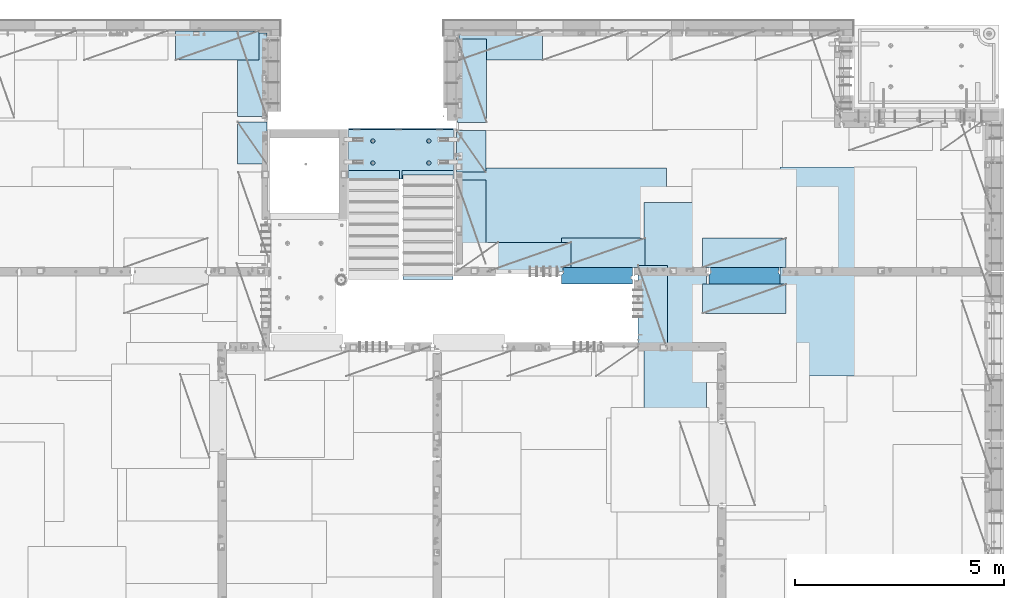
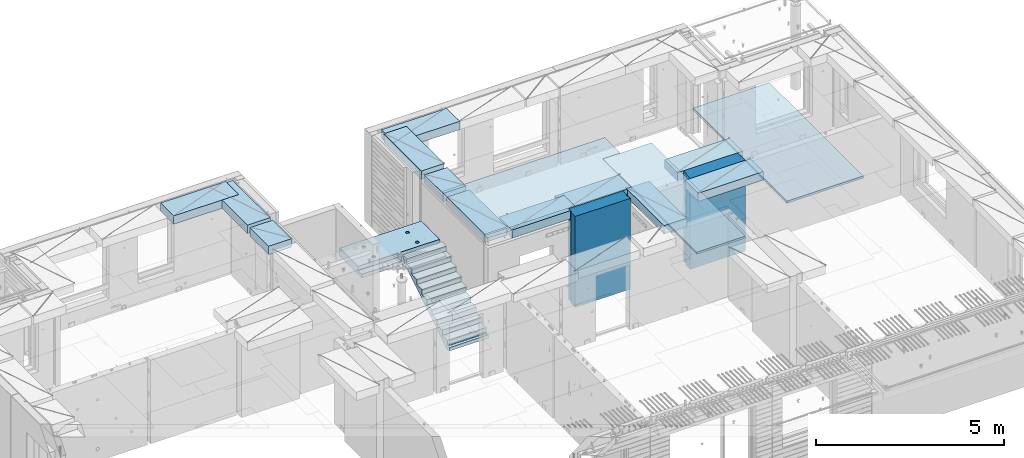
# One storey, part 200 of 334: 18 plates, 1 slab, 19 elements without a shape of their own.
"""IFC2X3 building model written with IfcOpenShell, lengths in millimetres."""

from ifc_helpers import new_model, si_unit, frame, origin_with_axes, place, context, subcontext, project, spatial, faceted_brep, material, type_object, element, aggregate, save


model = new_model("IFC2X3")

# Units and contexts
model_context = context("Model", 3, precision=1e-05, world=origin_with_axes())
body_context = subcontext(model_context, "Body", "Model", "MODEL_VIEW")
ifc_project = project(units=[si_unit("LENGTHUNIT", "METRE", prefix="MILLI"), si_unit("AREAUNIT", "SQUARE_METRE"), si_unit("VOLUMEUNIT", "CUBIC_METRE"), si_unit("MASSUNIT", "GRAM", prefix="KILO"), si_unit("TIMEUNIT", "SECOND"), si_unit("PLANEANGLEUNIT", "RADIAN"), si_unit("SOLIDANGLEUNIT", "STERADIAN"), si_unit("THERMODYNAMICTEMPERATUREUNIT", "DEGREE_CELSIUS"), si_unit("LUMINOUSINTENSITYUNIT", "LUMEN")], contexts=[model_context])

# Site, building, storey
site_placement = place(None, origin_with_axes())
site = spatial("IfcSite", under=ifc_project, at=site_placement, CompositionType="ELEMENT")
building_placement = place(site_placement, origin_with_axes())
building = spatial("IfcBuilding", under=site, at=building_placement, CompositionType="ELEMENT")
storey_placement = place(building_placement, origin_with_axes())
storey = spatial("IfcBuildingStorey", under=building, at=storey_placement, Name="3", CompositionType="ELEMENT", Elevation=0.0)

# Assembly, plate
assembly_1_placement = place(storey_placement, origin_with_axes())
assembly_1 = element("IfcElementAssembly", 1, at=assembly_1_placement, inside=storey, Name="E9", AssemblyPlace="NOTDEFINED", PredefinedType="NOTDEFINED")
ifc_material_1 = material(Name="Undefined/C32/40")
plate_type_1 = type_object("IfcPlateType", PredefinedType="NOTDEFINED")
plate_1_placement = place(assembly_1_placement, frame((21585.002175553, 16880.001025346, 87759.7036072969), z_axis=(0.0, 1.0, 0.0), x_axis=(0.0, 0.0, -1.0)))
plate_1 = element("IfcPlate", 2, at=plate_1_placement, type_object=plate_type_1, material=ifc_material_1, Name="E9", context=body_context, shape_type="Brep", body=[
    faceted_brep([(0.0, -600.0, 0.0), (0.0, -600.0, 30.0), (0.0, 600.0, 30.0), (0.0, 600.0, 0.0), (-136.699996948242, -600.0, 30.0), (-136.699996948242, 600.0, 30.0), (-136.699996948242, -600.0, 300.0), (-136.699996948242, 600.0, 300.0), (-303.399993896484, -600.0, 300.0), (-303.399993896484, 600.0, 300.0), (-303.399993896484, -600.0, 570.0), (-303.399993896484, 600.0, 570.0), (-470.100006103516, -600.0, 570.0), (-470.100006103516, 600.0, 570.0), (-470.100006103516, -600.0, 840.0), (-470.100006103516, 600.0, 840.0), (-636.799987792969, -600.0, 840.0), (-636.799987792969, 600.0, 840.0), (-636.799987792969, -600.0, 1110.0), (-636.799987792969, 600.0, 1110.0), (-803.5, -600.0, 1110.0), (-803.5, 600.0, 1110.0), (-803.5, -600.0, 1380.0), (-803.5, 600.0, 1380.0), (-970.200012207031, -600.0, 1380.0), (-970.200012207031, 600.0, 1380.0), (-970.200012207031, -600.0, 1650.0), (-970.200012207031, 600.0, 1650.0), (-1136.90002441406, -600.0, 1650.0), (-1136.90002441406, 600.0, 1650.0), (-1136.90002441406, -600.0, 1920.0), (-1136.90002441406, 600.0, 1920.0), (-1303.59997558594, -600.0, 1920.0), (-1303.59997558594, 600.0, 1920.0), (-1303.59997558594, -600.0, 2190.0), (-1303.59997558594, 600.0, 2190.0), (-1470.30004882813, -600.0, 2190.0), (-1470.30004882813, 600.0, 2190.0), (-1470.30004882813, -600.0, 2410.0), (-1470.30004882813, 600.0, 2410.0), (-1370.30004882813, -600.0, 2410.0), (-1370.30004882813, 600.0, 2410.0), (-1370.30004882813, -600.0, 2310.0), (-1370.30004882813, 600.0, 2310.0), (-1236.65991210938, -600.0, 2310.0), (-1236.65991210938, 600.0, 2310.0), (170.0, -600.0, 31.6665592193604), (170.0, 600.0, 31.6665592193604), (170.0, -600.0, 20.0), (170.0, 600.0, 20.0), (135.0, -600.0, 20.0), (135.0, 600.0, 20.0), (135.0, -600.0, -90.0), (135.0, 600.0, -90.0), (25.0, -600.0, -90.0), (25.0, 600.0, -90.0), (25.0, -600.0, 0.0), (25.0, 600.0, 0.0)], [[[0, 1, 2, 3]], [[1, 4, 5, 2]], [[4, 6, 7, 5]], [[6, 8, 9, 7]], [[8, 10, 11, 9]], [[10, 12, 13, 11]], [[12, 14, 15, 13]], [[14, 16, 17, 15]], [[16, 18, 19, 17]], [[18, 20, 21, 19]], [[20, 22, 23, 21]], [[22, 24, 25, 23]], [[24, 26, 27, 25]], [[26, 28, 29, 27]], [[28, 30, 31, 29]], [[30, 32, 33, 31]], [[32, 34, 35, 33]], [[34, 36, 37, 35]], [[36, 38, 39, 37]], [[38, 40, 41, 39]], [[40, 42, 43, 41]], [[42, 44, 45, 43]], [[44, 46, 47, 45]], [[46, 48, 49, 47]], [[48, 50, 51, 49]], [[50, 52, 53, 51]], [[52, 54, 55, 53]], [[54, 56, 57, 55]], [[56, 0, 3, 57]], [[5, 7, 9, 11, 13, 15, 17, 19, 21, 23, 25, 27, 29, 31, 33, 35, 37, 39, 41, 43, 45, 47, 49, 51, 53, 55, 57, 3, 2]], [[56, 54, 52, 50, 48, 46, 44, 42, 40, 38, 36, 34, 32, 30, 28, 26, 24, 22, 20, 18, 16, 14, 12, 10, 8, 6, 4, 1, 0]]]),
])
aggregate(assembly_1, [plate_1])

# Assembly, slab
assembly_2_placement = place(storey_placement, origin_with_axes())
assembly_2 = element("IfcElementAssembly", 3, at=assembly_2_placement, inside=storey, AssemblyPlace="NOTDEFINED", PredefinedType="REINFORCEMENT_UNIT")
ifc_material_2 = material(Name="CONCRETE/C25/30")
slab_type = type_object("IfcSlabType", PredefinedType="NOTDEFINED")
slab_placement = place(assembly_2_placement, frame((19680.000385927, 19200.0003517906, 89120.0), z_axis=(0.0, 1.0, 0.0), x_axis=(1.0, 0.0, 0.0)))
slab = element("IfcSlab", 4, at=slab_placement, type_object=slab_type, material=ifc_material_2, PredefinedType="FLOOR", context=body_context, shape_type="Brep", body=[
    faceted_brep([(1284.99890682963, -130.0, 0.0), (1284.99890682963, 10.0003972196719, 0.0), (1284.99890682963, 10.0003972196719, 200.003967285156), (1284.99890682963, -130.0, 200.003967285156), (2510.00073788432, 10.0003972196719, 200.003967285156), (2509.998046875, 10.0003972196719, 0.0), (2510.00073788432, -130.0, 200.003967285156), (2509.998046875, 60.0, 1210.00146484375), (0.0, 60.0, 1210.00146484375), (0.0, 50.0000001803419, 1180.00146538467), (2509.998046875, 50.0000001803419, 1180.00146538467), (2509.998046875, 130.0, 1210.00146484375), (0.0, 130.0, 1210.00146484375), (2509.998046875, 130.0, 0.0), (0.0, 130.0, -1.81898940354586e-12), (1225.00073788432, 10.0003972196719, 0.0), (1225.00073788432, 10.0003972196719, 200.003967285156), (-0.00109317036549328, 10.0003972196719, 200.003967285156), (0.0, 10.0003972196719, 0.0), (1225.00073788432, -130.0, 200.003967285156), (1225.00073788432, -130.0, 0.0), (0.0, -130.0, 200.003967285156), (0.0, -130.0, 1180.00146417833), (2509.998046875, -130.0, 1180.00146417833), (1940.44809334572, -110.0, 331.258272818675), (1954.3865062416, -110.0, 338.360248914683), (1965.44809334572, -110.0, 349.42183601881), (1972.55006944173, -110.0, 363.360248914683), (1974.99724362697, -110.0, 378.811098633432), (1972.55006944173, -110.0, 394.261948352181), (1965.44809334572, -110.0, 408.200361248055), (1954.3865062416, -110.0, 419.261948352181), (1940.44809334572, -110.0, 426.363924448189), (1924.99724362697, -110.0, 428.811098633432), (1909.54639390823, -110.0, 426.363924448189), (1895.60798101235, -110.0, 419.261948352181), (1884.54639390823, -110.0, 408.200361248055), (1877.44441781222, -110.0, 394.261948352181), (1874.99724362697, -110.0, 378.811098633432), (1877.44441781222, -110.0, 363.360248914683), (1884.54639390823, -110.0, 349.42183601881), (1895.60798101235, -110.0, 338.360248914683), (1909.54639390823, -110.0, 331.258272818675), (1924.99724362697, -110.0, 328.811098633432), (1974.71156152422, -130.0, 394.964259703032), (1977.2699708997, -130.0, 378.811098633432), (1967.28676833294, -130.0, 409.536236821448), (1955.72238181499, -130.0, 421.100623339393), (1941.15040469657, -130.0, 428.52541653068), (1924.99724362697, -130.0, 431.08382590616), (1908.84408255737, -130.0, 428.52541653068), (1894.27210543896, -130.0, 421.100623339393), (1882.70771892101, -130.0, 409.536236821448), (1875.28292572973, -130.0, 394.964259703032), (1872.72451635425, -130.0, 378.811098633432), (1875.28292572973, -130.0, 362.657937563832), (1882.70771892101, -130.0, 348.085960445416), (1894.27210543896, -130.0, 336.521573927472), (1908.84408255737, -130.0, 329.096780736185), (1924.99724362697, -130.0, 326.538371360704), (1941.15040469657, -130.0, 329.096780736185), (1955.72238181499, -130.0, 336.521573927472), (1967.28676833294, -130.0, 348.085960445416), (1974.71156152422, -130.0, 362.657937563832), (1940.44809334572, -110.0, 858.458272818676), (1954.3865062416, -110.0, 865.560248914684), (1965.44809334572, -110.0, 876.62183601881), (1972.55006944173, -110.0, 890.560248914684), (1974.99724362697, -110.0, 906.011098633433), (1972.55006944173, -110.0, 921.461948352182), (1965.44809334572, -110.0, 935.400361248056), (1954.3865062416, -110.0, 946.461948352182), (1940.44809334572, -110.0, 953.56392444819), (1924.99724362697, -110.0, 956.011098633433), (1909.54639390823, -110.0, 953.56392444819), (1895.60798101235, -110.0, 946.461948352182), (1884.54639390823, -110.0, 935.400361248056), (1877.44441781222, -110.0, 921.461948352182), (1874.99724362697, -110.0, 906.011098633433), (1877.44441781222, -110.0, 890.560248914684), (1884.54639390823, -110.0, 876.62183601881), (1895.60798101235, -110.0, 865.560248914684), (1909.54639390823, -110.0, 858.458272818676), (1924.99724362697, -110.0, 856.011098633433), (1974.71156152422, -130.0, 922.164259703033), (1977.2699708997, -130.0, 906.011098633433), (1967.28676833294, -130.0, 936.736236821449), (1955.72238181499, -130.0, 948.300623339394), (1941.15040469657, -130.0, 955.72541653068), (1924.99724362697, -130.0, 958.283825906161), (1908.84408255737, -130.0, 955.72541653068), (1894.27210543896, -130.0, 948.300623339394), (1882.70771892101, -130.0, 936.736236821449), (1875.28292572973, -130.0, 922.164259703033), (1872.72451635425, -130.0, 906.011098633433), (1875.28292572973, -130.0, 889.857937563833), (1882.70771892101, -130.0, 875.285960445417), (1894.27210543896, -130.0, 863.721573927472), (1908.84408255737, -130.0, 856.296780736186), (1924.99724362697, -130.0, 853.738371360705), (1941.15040469657, -130.0, 856.296780736186), (1955.72238181499, -130.0, 863.721573927472), (1967.28676833294, -130.0, 875.285960445417), (1974.71156152422, -130.0, 889.857937563833), (569.611134800252, -110.0, 426.363924448189), (555.672721904379, -110.0, 419.261948352181), (544.611134800252, -110.0, 408.200361248055), (537.509158704244, -110.0, 394.261948352181), (535.061984519001, -110.0, 378.811098633432), (537.509158704244, -110.0, 363.360248914683), (544.611134800252, -110.0, 349.42183601881), (555.672721904379, -110.0, 338.360248914683), (569.611134800252, -110.0, 331.258272818675), (585.061984519001, -110.0, 328.811098633432), (600.51283423775, -110.0, 331.258272818675), (614.451247133624, -110.0, 338.360248914683), (625.51283423775, -110.0, 349.42183601881), (632.614810333758, -110.0, 363.360248914683), (635.061984519001, -110.0, 378.811098633432), (632.614810333758, -110.0, 394.261948352181), (625.51283423775, -110.0, 408.200361248055), (614.451247133624, -110.0, 419.261948352181), (600.51283423775, -110.0, 426.363924448189), (585.061984519001, -110.0, 428.811098633432), (634.776302416249, -130.0, 394.964259703032), (637.334711791729, -130.0, 378.811098633432), (627.351509224962, -130.0, 409.536236821448), (615.787122707017, -130.0, 421.100623339393), (601.215145588601, -130.0, 428.52541653068), (585.061984519001, -130.0, 431.08382590616), (568.908823449401, -130.0, 428.52541653068), (554.336846330985, -130.0, 421.100623339393), (542.772459813041, -130.0, 409.536236821448), (535.347666621754, -130.0, 394.964259703032), (532.789257246273, -130.0, 378.811098633432), (535.347666621754, -130.0, 362.657937563832), (542.772459813041, -130.0, 348.085960445416), (554.336846330985, -130.0, 336.521573927472), (568.908823449401, -130.0, 329.096780736185), (585.061984519001, -130.0, 326.538371360704), (601.215145588601, -130.0, 329.096780736185), (615.787122707017, -130.0, 336.521573927472), (627.351509224962, -130.0, 348.085960445416), (634.776302416249, -130.0, 362.657937563832), (569.611134800252, -110.0, 953.56392444819), (555.672721904379, -110.0, 946.461948352182), (544.611134800252, -110.0, 935.400361248056), (537.509158704244, -110.0, 921.461948352182), (535.061984519001, -110.0, 906.011098633433), (537.509158704244, -110.0, 890.560248914684), (544.611134800252, -110.0, 876.62183601881), (555.672721904379, -110.0, 865.560248914684), (569.611134800252, -110.0, 858.458272818676), (585.061984519001, -110.0, 856.011098633433), (600.51283423775, -110.0, 858.458272818676), (614.451247133624, -110.0, 865.560248914684), (625.51283423775, -110.0, 876.62183601881), (632.614810333758, -110.0, 890.560248914684), (635.061984519001, -110.0, 906.011098633433), (632.614810333758, -110.0, 921.461948352182), (625.51283423775, -110.0, 935.400361248056), (614.451247133624, -110.0, 946.461948352182), (600.51283423775, -110.0, 953.56392444819), (585.061984519001, -110.0, 956.011098633433), (634.776302416249, -130.0, 922.164259703033), (637.334711791729, -130.0, 906.011098633433), (627.351509224962, -130.0, 936.736236821449), (615.787122707017, -130.0, 948.300623339394), (601.215145588601, -130.0, 955.72541653068), (585.061984519001, -130.0, 958.283825906161), (568.908823449401, -130.0, 955.72541653068), (554.336846330985, -130.0, 948.300623339394), (542.772459813041, -130.0, 936.736236821449), (535.347666621754, -130.0, 922.164259703033), (532.789257246273, -130.0, 906.011098633433), (535.347666621754, -130.0, 889.857937563833), (542.772459813041, -130.0, 875.285960445417), (554.336846330985, -130.0, 863.721573927472), (568.908823449401, -130.0, 856.296780736186), (585.061984519001, -130.0, 853.738371360705), (601.215145588601, -130.0, 856.296780736186), (615.787122707017, -130.0, 863.721573927472), (627.351509224962, -130.0, 875.285960445417), (634.776302416249, -130.0, 889.857937563833)], [[[0, 1, 2, 3]], [[4, 2, 1, 5]], [[6, 3, 2, 4]], [[7, 8, 9, 10]], [[11, 12, 8, 7]], [[11, 13, 14, 12]], [[15, 16, 17, 18]], [[19, 16, 15, 20]], [[21, 17, 16, 19]], [[22, 9, 8, 12, 14, 18, 17, 21]], [[23, 10, 9, 22]], [[5, 13, 11, 7, 10, 23, 6, 4]], [[0, 20, 15, 18, 14, 13, 5, 1]], [[24, 25, 26, 27, 28, 29, 30, 31, 32, 33, 34, 35, 36, 37, 38, 39, 40, 41, 42, 43]], [[44, 29, 28, 45]], [[46, 30, 29, 44]], [[47, 31, 30, 46]], [[48, 32, 31, 47]], [[49, 33, 32, 48]], [[50, 34, 33, 49]], [[51, 35, 34, 50]], [[52, 36, 35, 51]], [[53, 37, 36, 52]], [[54, 38, 37, 53]], [[55, 39, 38, 54]], [[56, 40, 39, 55]], [[57, 41, 40, 56]], [[58, 42, 41, 57]], [[59, 43, 42, 58]], [[60, 24, 43, 59]], [[61, 25, 24, 60]], [[62, 26, 25, 61]], [[63, 27, 26, 62]], [[45, 28, 27, 63]], [[64, 65, 66, 67, 68, 69, 70, 71, 72, 73, 74, 75, 76, 77, 78, 79, 80, 81, 82, 83]], [[84, 69, 68, 85]], [[86, 70, 69, 84]], [[87, 71, 70, 86]], [[88, 72, 71, 87]], [[89, 73, 72, 88]], [[90, 74, 73, 89]], [[91, 75, 74, 90]], [[92, 76, 75, 91]], [[93, 77, 76, 92]], [[94, 78, 77, 93]], [[95, 79, 78, 94]], [[96, 80, 79, 95]], [[97, 81, 80, 96]], [[98, 82, 81, 97]], [[99, 83, 82, 98]], [[100, 64, 83, 99]], [[101, 65, 64, 100]], [[102, 66, 65, 101]], [[103, 67, 66, 102]], [[85, 68, 67, 103]], [[104, 105, 106, 107, 108, 109, 110, 111, 112, 113, 114, 115, 116, 117, 118, 119, 120, 121, 122, 123]], [[124, 119, 118, 125]], [[126, 120, 119, 124]], [[127, 121, 120, 126]], [[128, 122, 121, 127]], [[129, 123, 122, 128]], [[130, 104, 123, 129]], [[131, 105, 104, 130]], [[132, 106, 105, 131]], [[133, 107, 106, 132]], [[134, 108, 107, 133]], [[135, 109, 108, 134]], [[136, 110, 109, 135]], [[137, 111, 110, 136]], [[138, 112, 111, 137]], [[139, 113, 112, 138]], [[140, 114, 113, 139]], [[141, 115, 114, 140]], [[142, 116, 115, 141]], [[143, 117, 116, 142]], [[125, 118, 117, 143]], [[144, 145, 146, 147, 148, 149, 150, 151, 152, 153, 154, 155, 156, 157, 158, 159, 160, 161, 162, 163]], [[164, 159, 158, 165]], [[166, 160, 159, 164]], [[167, 161, 160, 166]], [[168, 162, 161, 167]], [[169, 163, 162, 168]], [[170, 144, 163, 169]], [[171, 145, 144, 170]], [[172, 146, 145, 171]], [[173, 147, 146, 172]], [[174, 148, 147, 173]], [[175, 149, 148, 174]], [[176, 150, 149, 175]], [[177, 151, 150, 176]], [[178, 152, 151, 177]], [[179, 153, 152, 178]], [[180, 154, 153, 179]], [[181, 155, 154, 180]], [[182, 156, 155, 181]], [[183, 157, 156, 182]], [[165, 158, 157, 183]], [[23, 22, 21, 19, 20, 0, 3, 6], [182, 181, 180, 179, 178, 177, 176, 175, 174, 173, 172, 171, 170, 169, 168, 167, 166, 164, 165, 183], [142, 141, 140, 139, 138, 137, 136, 135, 134, 133, 132, 131, 130, 129, 128, 127, 126, 124, 125, 143], [102, 101, 100, 99, 98, 97, 96, 95, 94, 93, 92, 91, 90, 89, 88, 87, 86, 84, 85, 103], [62, 61, 60, 59, 58, 57, 56, 55, 54, 53, 52, 51, 50, 49, 48, 47, 46, 44, 45, 63]]]),
])
aggregate(assembly_2, [slab])

# Assembly, plate
assembly_3_placement = place(storey_placement, origin_with_axes())
assembly_3 = element("IfcElementAssembly", 5, at=assembly_3_placement, inside=storey, Name="Steel Assembly", AssemblyPlace="NOTDEFINED", PredefinedType="NOTDEFINED")
ifc_material_3 = material()
plate_type_2 = type_object("IfcPlateType", PredefinedType="NOTDEFINED")
plate_2_placement = place(assembly_3_placement, frame((22289.9998779297, 19460.0009765625, 90695.1), z_axis=(1.0, 0.0, 0.0), x_axis=(0.0, -1.0, 0.0)))
plate_2 = element("IfcPlate", 6, at=plate_2_placement, type_object=plate_type_2, material=ifc_material_3, context=body_context, shape_type="Brep", body=[
    faceted_brep([(0.0, -35.0, 0.0), (0.0, -35.0, 5000.0), (0.0, 35.0, 5000.0), (0.0, 35.0, 0.0), (2349.99951171875, -35.0, 5000.0), (2349.99951171875, 35.0, 5000.0), (2350.0, -35.0, 0.0), (2350.0, 35.0, 0.0)], [[[0, 1, 2, 3]], [[1, 4, 5, 2]], [[4, 6, 7, 5]], [[6, 0, 3, 7]], [[5, 7, 3, 2]], [[6, 4, 1, 0]]]),
])
aggregate(assembly_3, [plate_2])

assembly_4_placement = place(storey_placement, origin_with_axes())
assembly_4 = element("IfcElementAssembly", 7, at=assembly_4_placement, inside=storey, Name="Steel Assembly", AssemblyPlace="NOTDEFINED", PredefinedType="NOTDEFINED")
plate_3_placement = place(assembly_4_placement, frame((32360.0, 19480.0, 90695.1), z_axis=(0.0, -1.0, 0.0), x_axis=(-1.0, 3.00000001838171e-08, 0.0)))
plate_3 = element("IfcPlate", 8, at=plate_3_placement, type_object=plate_type_2, material=ifc_material_3, context=body_context, shape_type="Brep", body=[
    faceted_brep([(0.0, -35.0, 0.0), (0.0, -35.0, 5000.0), (0.0, 35.0, 5000.0), (0.0, 35.0, 0.0), (2349.99951171875, -35.0, 5000.0), (2349.99951171875, 35.0, 5000.0), (2350.0, -35.0, 0.0), (2350.0, 35.0, 0.0)], [[[0, 1, 2, 3]], [[1, 4, 5, 2]], [[4, 6, 7, 5]], [[6, 0, 3, 7]], [[5, 7, 3, 2]], [[6, 4, 1, 0]]]),
])
aggregate(assembly_4, [plate_3])

assembly_5_placement = place(storey_placement, origin_with_axes())
assembly_5 = element("IfcElementAssembly", 9, at=assembly_5_placement, inside=storey, Name="Steel Assembly", AssemblyPlace="NOTDEFINED", PredefinedType="NOTDEFINED")
plate_type_3 = type_object("IfcPlateType", PredefinedType="NOTDEFINED")
plate_4_placement = place(assembly_5_placement, frame((28250.0000122641, 18630.0, 90695.1000003815), z_axis=(0.0, -1.0, 0.0), x_axis=(-1.0, 3.00000001838171e-08, 0.0)))
plate_4 = element("IfcPlate", 10, at=plate_4_placement, type_object=plate_type_3, material=ifc_material_3, context=body_context, shape_type="Brep", body=[
    faceted_brep([(0.0, -35.0, 0.0), (0.0, -35.0, 5000.0), (0.0, 35.0, 5000.0), (0.0, 35.0, 0.0), (1499.99951171875, -35.0, 5000.0), (1499.99951171875, 35.0, 5000.0), (1500.0, -35.0, 0.0), (1500.0, 35.0, 0.0)], [[[0, 1, 2, 3]], [[1, 4, 5, 2]], [[4, 6, 7, 5]], [[6, 0, 3, 7]], [[5, 7, 3, 2]], [[6, 4, 1, 0]]]),
])
aggregate(assembly_5, [plate_4])

assembly_6_placement = place(storey_placement, origin_with_axes())
assembly_6 = element("IfcElementAssembly", 11, at=assembly_6_placement, inside=storey, Name="Steel Assembly", AssemblyPlace="NOTDEFINED", PredefinedType="NOTDEFINED")
plate_type_4 = type_object("IfcPlateType", PredefinedType="NOTDEFINED")
plate_5_placement = place(assembly_6_placement, frame((24330.0, 22740.0001220703, 90595.3), z_axis=(0.0, -1.0, 0.0), x_axis=(-1.0, 3.00000001838171e-08, 0.0)))
plate_5 = element("IfcPlate", 12, at=plate_5_placement, type_object=plate_type_4, material=ifc_material_3, Name="RE1", context=body_context, shape_type="Brep", body=[
    faceted_brep([(1.81898940354586e-12, -135.0, 1.81898940354586e-12), (0.0, -135.0, 699.999999999996), (0.0, 135.0, 699.999999999996), (1.81898940354586e-12, 135.0, 1.81898940354586e-12), (1999.99951171875, -135.0, 699.999999999993), (1999.99951171875, 135.0, 699.999999999993), (2000.0, -135.0, -3.63797880709171e-12), (2000.0, 135.0, -3.63797880709171e-12)], [[[0, 1, 2, 3]], [[1, 4, 5, 2]], [[4, 6, 7, 5]], [[6, 0, 3, 7]], [[5, 7, 3, 2]], [[6, 4, 1, 0]]]),
])
aggregate(assembly_6, [plate_5])

assembly_7_placement = place(storey_placement, origin_with_axes())
assembly_7 = element("IfcElementAssembly", 13, at=assembly_7_placement, inside=storey, Name="Steel Assembly", AssemblyPlace="NOTDEFINED", PredefinedType="NOTDEFINED")
plate_6_placement = place(assembly_7_placement, frame((17730.0001220703, 20690.0, 90595.3), z_axis=(-1.0, 3.00000001838171e-08, 0.0), x_axis=(0.0, 1.0, 0.0)))
plate_6 = element("IfcPlate", 14, at=plate_6_placement, type_object=plate_type_4, material=ifc_material_3, Name="RE1", context=body_context, shape_type="Brep", body=[
    faceted_brep([(1.81898940354586e-12, -135.0, 1.81898940354586e-12), (0.0, -135.0, 699.999999999996), (0.0, 135.0, 699.999999999996), (1.81898940354586e-12, 135.0, 1.81898940354586e-12), (1999.99951171875, -135.0, 699.999999999993), (1999.99951171875, 135.0, 699.999999999993), (2000.0, -135.0, -3.63797880709171e-12), (2000.0, 135.0, -3.63797880709171e-12)], [[[0, 1, 2, 3]], [[1, 4, 5, 2]], [[4, 6, 7, 5]], [[6, 0, 3, 7]], [[5, 7, 3, 2]], [[6, 4, 1, 0]]]),
])
aggregate(assembly_7, [plate_6])

assembly_8_placement = place(storey_placement, origin_with_axes())
assembly_8 = element("IfcElementAssembly", 15, at=assembly_8_placement, inside=storey, Name="Steel Assembly", AssemblyPlace="NOTDEFINED", PredefinedType="NOTDEFINED")
plate_7_placement = place(assembly_8_placement, frame((22269.9998779297, 19170.0, 90595.3), z_axis=(1.0, 0.0, 0.0), x_axis=(0.0, -1.0, 0.0)))
plate_7 = element("IfcPlate", 16, at=plate_7_placement, type_object=plate_type_4, material=ifc_material_3, Name="RE1", context=body_context, shape_type="Brep", body=[
    faceted_brep([(1.81898940354586e-12, -135.0, 1.81898940354586e-12), (0.0, -135.0, 699.999999999996), (0.0, 135.0, 699.999999999996), (1.81898940354586e-12, 135.0, 1.81898940354586e-12), (1999.99951171875, -135.0, 699.999999999993), (1999.99951171875, 135.0, 699.999999999993), (2000.0, -135.0, -3.63797880709171e-12), (2000.0, 135.0, -3.63797880709171e-12)], [[[0, 1, 2, 3]], [[1, 4, 5, 2]], [[4, 6, 7, 5]], [[6, 0, 3, 7]], [[5, 7, 3, 2]], [[6, 4, 1, 0]]]),
])
aggregate(assembly_8, [plate_7])

assembly_9_placement = place(storey_placement, origin_with_axes())
assembly_9 = element("IfcElementAssembly", 17, at=assembly_9_placement, inside=storey, Name="Steel Assembly", AssemblyPlace="NOTDEFINED", PredefinedType="NOTDEFINED")
plate_8_placement = place(assembly_9_placement, frame((22289.9998779297, 22550.0, 90595.3), z_axis=(1.0, 0.0, 0.0), x_axis=(0.0, -1.0, 0.0)))
plate_8 = element("IfcPlate", 18, at=plate_8_placement, type_object=plate_type_4, material=ifc_material_3, Name="RE1", context=body_context, shape_type="Brep", body=[
    faceted_brep([(1.81898940354586e-12, -135.0, 1.81898940354586e-12), (0.0, -135.0, 699.999999999996), (0.0, 135.0, 699.999999999996), (1.81898940354586e-12, 135.0, 1.81898940354586e-12), (1999.99951171875, -135.0, 699.999999999993), (1999.99951171875, 135.0, 699.999999999993), (2000.0, -135.0, -3.63797880709171e-12), (2000.0, 135.0, -3.63797880709171e-12)], [[[0, 1, 2, 3]], [[1, 4, 5, 2]], [[4, 6, 7, 5]], [[6, 0, 3, 7]], [[5, 7, 3, 2]], [[6, 4, 1, 0]]]),
])
aggregate(assembly_9, [plate_8])

assembly_10_placement = place(storey_placement, origin_with_axes())
assembly_10 = element("IfcElementAssembly", 19, at=assembly_10_placement, inside=storey, Name="Steel Assembly", AssemblyPlace="NOTDEFINED", PredefinedType="NOTDEFINED")
plate_9_placement = place(assembly_10_placement, frame((22269.9999999293, 20360.0, 90595.3), z_axis=(1.0, 0.0, 0.0), x_axis=(0.0, -1.0, 0.0)))
plate_9 = element("IfcPlate", 20, at=plate_9_placement, type_object=plate_type_4, material=ifc_material_3, Name="RE1_1/2", context=body_context, shape_type="Brep", body=[
    faceted_brep([(1.81898940354586e-12, -135.0, 1.81898940354586e-12), (0.0, -135.0, 699.999999999996), (0.0, 135.0, 699.999999999996), (1.81898940354586e-12, 135.0, 1.81898940354586e-12), (999.99951171875, -135.0, 700.0), (999.99951171875, 135.0, 700.0), (1000.0, -135.0, 0.0), (1000.0, 135.0, 0.0)], [[[0, 1, 2, 3]], [[1, 4, 5, 2]], [[4, 6, 7, 5]], [[6, 0, 3, 7]], [[5, 7, 3, 2]], [[6, 4, 1, 0]]]),
])
aggregate(assembly_10, [plate_9])

assembly_11_placement = place(storey_placement, origin_with_axes())
assembly_11 = element("IfcElementAssembly", 21, at=assembly_11_placement, inside=storey, Name="Steel Assembly", AssemblyPlace="NOTDEFINED", PredefinedType="NOTDEFINED")
plate_10_placement = place(assembly_11_placement, frame((23010.0008542386, 16980.0001036336, 90595.3), z_axis=(0.0, 1.0, 0.0), x_axis=(1.0, 0.0, 0.0)))
plate_10 = element("IfcPlate", 22, at=plate_10_placement, type_object=plate_type_4, material=ifc_material_3, Name="RE1", context=body_context, shape_type="Brep", body=[
    faceted_brep([(1.81898940354586e-12, -135.0, 1.81898940354586e-12), (0.0, -135.0, 699.999999999996), (0.0, 135.0, 699.999999999996), (1.81898940354586e-12, 135.0, 1.81898940354586e-12), (1999.99951171875, -135.0, 699.999999999993), (1999.99951171875, 135.0, 699.999999999993), (2000.0, -135.0, -3.63797880709171e-12), (2000.0, 135.0, -3.63797880709171e-12)], [[[0, 1, 2, 3]], [[1, 4, 5, 2]], [[4, 6, 7, 5]], [[6, 0, 3, 7]], [[5, 7, 3, 2]], [[6, 4, 1, 0]]]),
])
aggregate(assembly_11, [plate_10])

assembly_12_placement = place(storey_placement, origin_with_axes())
assembly_12 = element("IfcElementAssembly", 23, at=assembly_12_placement, inside=storey, Name="Steel Assembly", AssemblyPlace="NOTDEFINED", PredefinedType="NOTDEFINED")
plate_11_placement = place(assembly_12_placement, frame((30152.4991457614, 16679.9998963664, 90595.3), z_axis=(0.0, -1.0, 0.0), x_axis=(-1.0, 3.00000001838171e-08, 0.0)))
plate_11 = element("IfcPlate", 24, at=plate_11_placement, type_object=plate_type_4, material=ifc_material_3, Name="RE1", context=body_context, shape_type="Brep", body=[
    faceted_brep([(1.81898940354586e-12, -135.0, 1.81898940354586e-12), (0.0, -135.0, 699.999999999996), (0.0, 135.0, 699.999999999996), (1.81898940354586e-12, 135.0, 1.81898940354586e-12), (1999.99951171875, -135.0, 699.999999999993), (1999.99951171875, 135.0, 699.999999999993), (2000.0, -135.0, -3.63797880709171e-12), (2000.0, 135.0, -3.63797880709171e-12)], [[[0, 1, 2, 3]], [[1, 4, 5, 2]], [[4, 6, 7, 5]], [[6, 0, 3, 7]], [[5, 7, 3, 2]], [[6, 4, 1, 0]]]),
])
aggregate(assembly_12, [plate_11])

assembly_13_placement = place(storey_placement, origin_with_axes())
assembly_13 = element("IfcElementAssembly", 25, at=assembly_13_placement, inside=storey, Name="Steel Assembly", AssemblyPlace="NOTDEFINED", PredefinedType="NOTDEFINED")
plate_12_placement = place(assembly_13_placement, frame((28152.5008542386, 17080.0001036336, 90595.3), z_axis=(0.0, 1.0, 0.0), x_axis=(1.0, 0.0, 0.0)))
plate_12 = element("IfcPlate", 26, at=plate_12_placement, type_object=plate_type_4, material=ifc_material_3, Name="RE1", context=body_context, shape_type="Brep", body=[
    faceted_brep([(1.81898940354586e-12, -135.0, 1.81898940354586e-12), (0.0, -135.0, 699.999999999996), (0.0, 135.0, 699.999999999996), (1.81898940354586e-12, 135.0, 1.81898940354586e-12), (1999.99951171875, -135.0, 699.999999999993), (1999.99951171875, 135.0, 699.999999999993), (2000.0, -135.0, -3.63797880709171e-12), (2000.0, 135.0, -3.63797880709171e-12)], [[[0, 1, 2, 3]], [[1, 4, 5, 2]], [[4, 6, 7, 5]], [[6, 0, 3, 7]], [[5, 7, 3, 2]], [[6, 4, 1, 0]]]),
])
aggregate(assembly_13, [plate_12])

assembly_14_placement = place(storey_placement, origin_with_axes())
assembly_14 = element("IfcElementAssembly", 27, at=assembly_14_placement, inside=storey, Name="Steel Assembly", AssemblyPlace="NOTDEFINED", PredefinedType="NOTDEFINED")
plate_13_placement = place(assembly_14_placement, frame((24780.0008542386, 17080.0001036336, 90595.3), z_axis=(0.0, 1.0, 0.0), x_axis=(1.0, 0.0, 0.0)))
plate_13 = element("IfcPlate", 28, at=plate_13_placement, type_object=plate_type_4, material=ifc_material_3, Name="RE1", context=body_context, shape_type="Brep", body=[
    faceted_brep([(1.81898940354586e-12, -135.0, 1.81898940354586e-12), (0.0, -135.0, 699.999999999996), (0.0, 135.0, 699.999999999996), (1.81898940354586e-12, 135.0, 1.81898940354586e-12), (1999.99951171875, -135.0, 699.999999999993), (1999.99951171875, 135.0, 699.999999999993), (2000.0, -135.0, -3.63797880709171e-12), (2000.0, 135.0, -3.63797880709171e-12)], [[[0, 1, 2, 3]], [[1, 4, 5, 2]], [[4, 6, 7, 5]], [[6, 0, 3, 7]], [[5, 7, 3, 2]], [[6, 4, 1, 0]]]),
])
aggregate(assembly_14, [plate_13])

assembly_15_placement = place(storey_placement, origin_with_axes())
assembly_15 = element("IfcElementAssembly", 29, at=assembly_15_placement, inside=storey, Name="Steel Assembly", AssemblyPlace="NOTDEFINED", PredefinedType="NOTDEFINED")
plate_14_placement = place(assembly_15_placement, frame((26609.9998779297, 17130.0, 90595.3), z_axis=(1.0, 0.0, 0.0), x_axis=(0.0, -1.0, 0.0)))
plate_14 = element("IfcPlate", 30, at=plate_14_placement, type_object=plate_type_4, material=ifc_material_3, Name="RE1", context=body_context, shape_type="Brep", body=[
    faceted_brep([(1.81898940354586e-12, -135.0, 1.81898940354586e-12), (0.0, -135.0, 699.999999999996), (0.0, 135.0, 699.999999999996), (1.81898940354586e-12, 135.0, 1.81898940354586e-12), (1999.99951171875, -135.0, 699.999999999993), (1999.99951171875, 135.0, 699.999999999993), (2000.0, -135.0, -3.63797880709171e-12), (2000.0, 135.0, -3.63797880709171e-12)], [[[0, 1, 2, 3]], [[1, 4, 5, 2]], [[4, 6, 7, 5]], [[6, 0, 3, 7]], [[5, 7, 3, 2]], [[6, 4, 1, 0]]]),
])
aggregate(assembly_15, [plate_14])

assembly_16_placement = place(storey_placement, origin_with_axes())
assembly_16 = element("IfcElementAssembly", 31, at=assembly_16_placement, inside=storey, Name="Steel Assembly", AssemblyPlace="NOTDEFINED", PredefinedType="NOTDEFINED")
plate_15_placement = place(assembly_16_placement, frame((17730.0000000707, 19560.0, 90595.3), z_axis=(-1.0, 3.00000001838171e-08, 0.0), x_axis=(0.0, 1.0, 0.0)))
plate_15 = element("IfcPlate", 32, at=plate_15_placement, type_object=plate_type_4, material=ifc_material_3, Name="RE1_1/2", context=body_context, shape_type="Brep", body=[
    faceted_brep([(1.81898940354586e-12, -135.0, 1.81898940354586e-12), (0.0, -135.0, 699.999999999996), (0.0, 135.0, 699.999999999996), (1.81898940354586e-12, 135.0, 1.81898940354586e-12), (999.99951171875, -135.0, 700.0), (999.99951171875, 135.0, 700.0), (1000.0, -135.0, 0.0), (1000.0, 135.0, 0.0)], [[[0, 1, 2, 3]], [[1, 4, 5, 2]], [[4, 6, 7, 5]], [[6, 0, 3, 7]], [[5, 7, 3, 2]], [[6, 4, 1, 0]]]),
])
aggregate(assembly_16, [plate_15])

assembly_17_placement = place(storey_placement, origin_with_axes())
assembly_17 = element("IfcElementAssembly", 33, at=assembly_17_placement, inside=storey, Name="Steel Assembly", AssemblyPlace="NOTDEFINED", PredefinedType="NOTDEFINED")
plate_16_placement = place(assembly_17_placement, frame((17545.0, 22740.0001220703, 90595.3), z_axis=(0.0, -1.0, 0.0), x_axis=(-1.0, 3.00000001838171e-08, 0.0)))
plate_16 = element("IfcPlate", 34, at=plate_16_placement, type_object=plate_type_4, material=ifc_material_3, Name="RE1", context=body_context, shape_type="Brep", body=[
    faceted_brep([(1.81898940354586e-12, -135.0, 1.81898940354586e-12), (0.0, -135.0, 699.999999999996), (0.0, 135.0, 699.999999999996), (1.81898940354586e-12, 135.0, 1.81898940354586e-12), (1999.99951171875, -135.0, 699.999999999993), (1999.99951171875, 135.0, 699.999999999993), (2000.0, -135.0, -3.63797880709171e-12), (2000.0, 135.0, -3.63797880709171e-12)], [[[0, 1, 2, 3]], [[1, 4, 5, 2]], [[4, 6, 7, 5]], [[6, 0, 3, 7]], [[5, 7, 3, 2]], [[6, 4, 1, 0]]]),
])
aggregate(assembly_17, [plate_16])

assembly_18_placement = place(storey_placement, origin_with_axes())
assembly_18 = element("IfcElementAssembly", 35, at=assembly_18_placement, inside=storey, Name="Steel Assembly", AssemblyPlace="NOTDEFINED", PredefinedType="NOTDEFINED")
ifc_material_4 = material()
plate_type_5 = type_object("IfcPlateType", PredefinedType="NOTDEFINED")
plate_17_placement = place(assembly_18_placement, frame((24780.0, 16680.0, 89255.6000003815), z_axis=(0.0, 1.0, 0.0), x_axis=(1.0, 0.0, 0.0)))
plate_17 = element("IfcPlate", 36, at=plate_17_placement, type_object=plate_type_5, material=ifc_material_4, context=body_context, shape_type="Brep", body=[
    faceted_brep([(1699.99914550781, -1475.0, 110.0), (1699.99914550781, 1475.0, 110.0), (1669.99914550781, 1475.0, 110.0), (1669.99914550781, -1475.00000000001, 110.0), (1669.99914550781, 1475.0, 200.0), (1669.99914550781, -1475.00000000001, 200.0), (1699.99914550781, -1475.0, 200.0), (1699.99914550781, 1475.0, 200.0), (1699.99914550781, -1475.0, 3.63797880709171e-12), (0.0, -1475.0, 0.0), (0.0, 1475.0, 0.0), (1699.99914550781, 1475.0, 3.63797880709171e-12), (0.0, -1475.0, 230.0), (0.0, 1475.0, 230.0), (30.0, -1475.0, 243.0), (30.0, 1475.0, 243.0), (30.0, -1475.0, 400.0), (30.0, 1475.0, 400.0), (1699.99914550781, -1475.0, 400.0), (1699.99914550781, 1475.0, 400.0)], [[[0, 1, 2, 3]], [[3, 2, 4, 5]], [[6, 5, 4, 7]], [[8, 9, 10, 11]], [[10, 9, 12, 13]], [[14, 15, 13, 12]], [[16, 17, 15, 14]], [[18, 19, 17, 16]], [[19, 18, 6, 7]], [[2, 1, 11, 10, 13, 15, 17, 19, 7, 4]], [[8, 11, 1, 0]], [[18, 16, 14, 12, 9, 8, 0, 3, 5, 6]]]),
])
aggregate(assembly_18, [plate_17])

assembly_19_placement = place(storey_placement, origin_with_axes())
assembly_19 = element("IfcElementAssembly", 37, at=assembly_19_placement, inside=storey, Name="Steel Assembly", AssemblyPlace="NOTDEFINED", PredefinedType="NOTDEFINED")
plate_18_placement = place(assembly_19_placement, frame((28309.9999105288, 16680.0000293051, 89255.6000003815), z_axis=(0.0, 1.0, 0.0), x_axis=(1.0, 0.0, 0.0)))
plate_18 = element("IfcPlate", 38, at=plate_18_placement, type_object=plate_type_5, material=ifc_material_4, context=body_context, shape_type="Brep", body=[
    faceted_brep([(29.9999989126591, -1475.0, 243.000885767418), (29.9999989126591, 1475.0, 243.000885767418), (0.0, 1475.0, 230.000886222213), (0.0, -1475.0, 230.000886222213), (30.0000025741901, -1475.0, 399.999635204884), (30.0000025741901, 1475.0, 399.999633789063), (1700.00073242188, -1475.0, 0.0), (0.0, -1475.0, 0.0), (0.0, 1475.0, 0.0), (1700.00073242188, 1475.0, 0.0), (1700.00073242188, 1475.0, 230.001129150391), (1700.00041094652, -1475.0, 230.001129150391), (1670.00041094652, 1475.0, 243.001129150391), (1670.00041094652, -1475.0, 243.001129150391), (1670.00041094652, -1475.0, 399.999633789063), (1670.00041094652, 1475.0, 399.999633789063)], [[[0, 1, 2, 3]], [[4, 5, 1, 0]], [[6, 7, 8, 9]], [[6, 9, 10, 11]], [[11, 10, 12, 13]], [[14, 13, 12, 15]], [[3, 7, 6, 11, 13, 14, 4, 0]], [[8, 7, 3, 2]], [[15, 12, 10, 9, 8, 2, 1, 5]], [[14, 15, 5, 4]]]),
])
aggregate(assembly_19, [plate_18])

save(model, "model.ifc")
